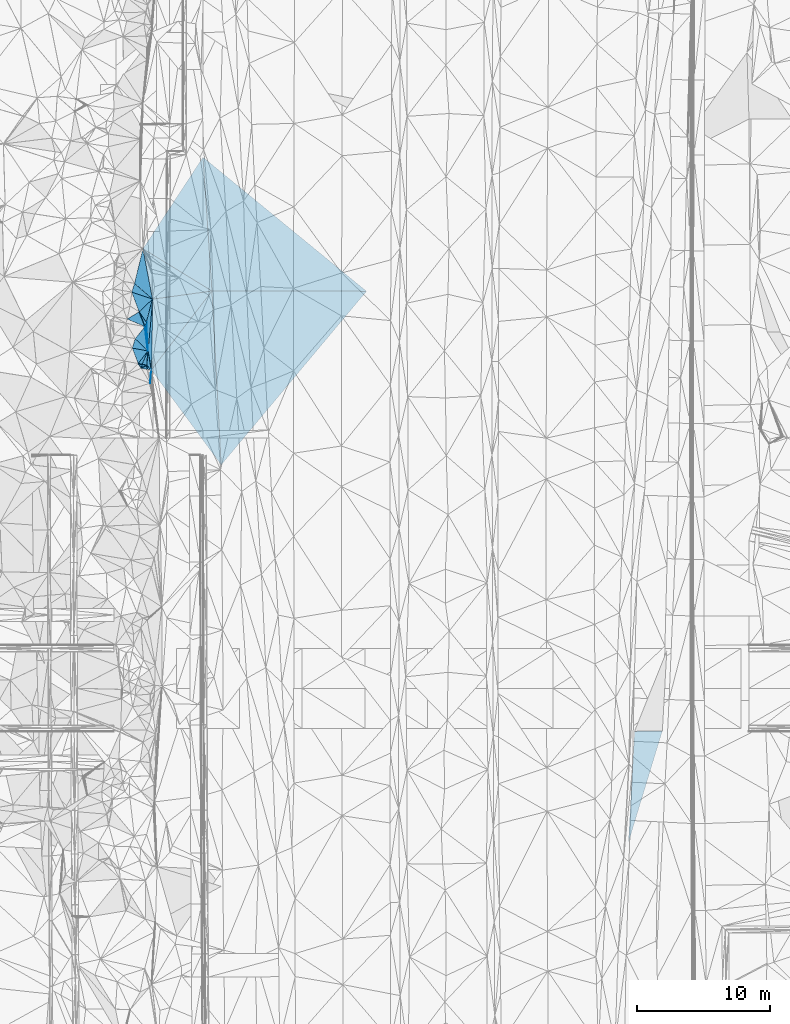
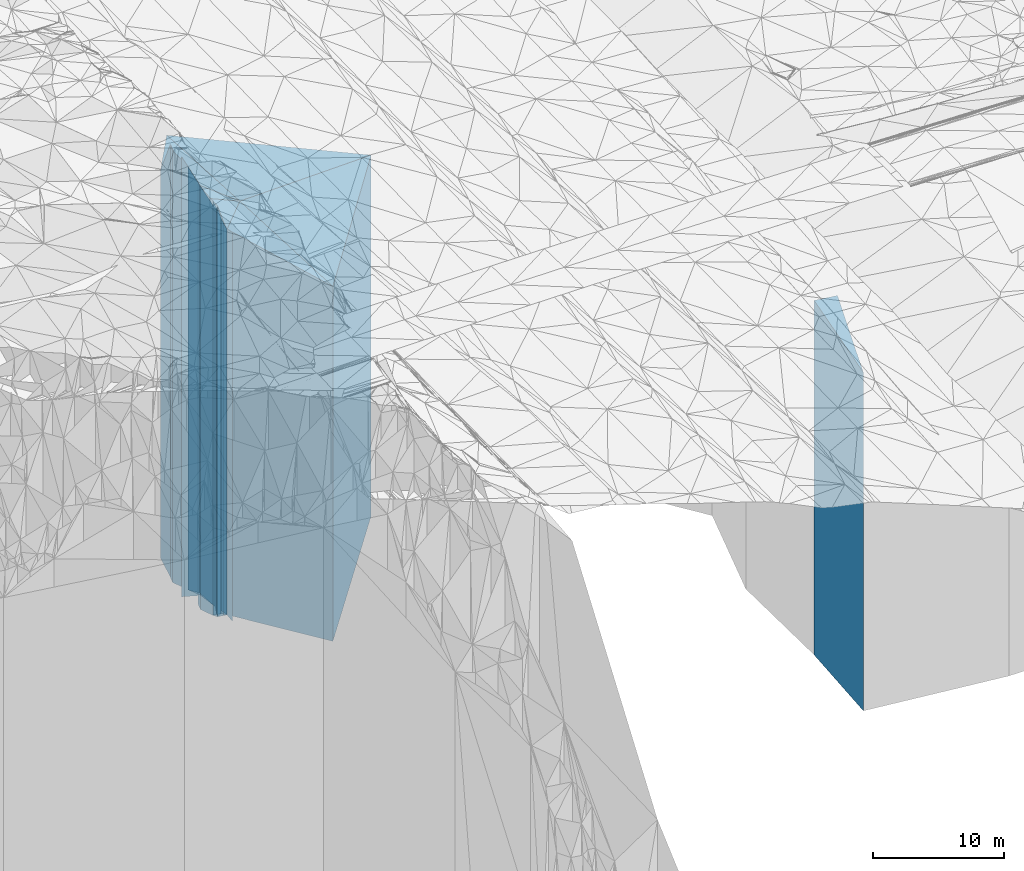
# One storey, part 252 of 275: 27 plates.
"""IFC2X3 building model written with IfcOpenShell, lengths in millimetres."""

from ifc_helpers import new_model, si_unit, frame, origin_with_axes, place, context, subcontext, project, spatial, faceted_brep, material, type_object, element, save


model = new_model("IFC2X3")

# Units and contexts
model_context = context("Model", 3, precision=1e-05, world=origin_with_axes())
body_context = subcontext(model_context, "Body", "Model", "MODEL_VIEW")
ifc_project = project(units=[si_unit("LENGTHUNIT", "METRE", prefix="MILLI"), si_unit("AREAUNIT", "SQUARE_METRE"), si_unit("VOLUMEUNIT", "CUBIC_METRE"), si_unit("MASSUNIT", "GRAM", prefix="KILO"), si_unit("TIMEUNIT", "SECOND"), si_unit("PLANEANGLEUNIT", "RADIAN"), si_unit("SOLIDANGLEUNIT", "STERADIAN"), si_unit("THERMODYNAMICTEMPERATUREUNIT", "DEGREE_CELSIUS"), si_unit("LUMINOUSINTENSITYUNIT", "LUMEN")], contexts=[model_context])

# Site, building, storey
site_placement = place(None, origin_with_axes())
site = spatial("IfcSite", under=ifc_project, at=site_placement, CompositionType="ELEMENT")
building_placement = place(site_placement, origin_with_axes())
building = spatial("IfcBuilding", under=site, at=building_placement, Name="Undefined", CompositionType="ELEMENT")
storey_placement = place(building_placement, origin_with_axes())
storey = spatial("IfcBuildingStorey", under=building, at=storey_placement, Name="Undefined", CompositionType="ELEMENT", Elevation=0.0)

# Plates
ifc_material = material()
plate_type_1 = type_object("IfcPlateType", PredefinedType="NOTDEFINED")
plate_1_placement = place(storey_placement, frame((-94152.6984096096, 103099.353531321, 24553.0), z_axis=(0.997762925662043, 0.0668516579773562, 0.0), x_axis=(0.0668516579773567, -0.997762925662043, 0.0)))
element("IfcPlate", 1, at=plate_1_placement, inside=storey, type_object=plate_type_1, material=ifc_material, Name="00", context=body_context, shape_type="Brep", body=[
    faceted_brep([(0.0, -17039.6099853516, 0.0), (10847.771484375, -16986.3760070801, 11560.4423828125), (10847.771484375, 16725.0, 11560.4423828125), (0.0, 16725.0, 0.0), (10054.0888671875, -16725.0, 7.13043846189976e-10), (10054.0888671875, 16725.0, 7.13043846189976e-10)], [[[0, 1, 2, 3]], [[1, 4, 5, 2]], [[4, 0, 3, 5]], [[5, 3, 2]], [[4, 1, 0]]]),
])
plate_type_2 = type_object("IfcPlateType", PredefinedType="NOTDEFINED")
plate_2_placement = place(storey_placement, frame((-81892.9256122936, 93048.6836211359, 24399.5), z_axis=(-0.0016459390007212, -0.999998645441486, 0.0), x_axis=(-0.999998645441486, 0.00164593900072622, 0.0)))
element("IfcPlate", 2, at=plate_2_placement, inside=storey, type_object=plate_type_2, material=ifc_material, Name="00", context=body_context, shape_type="Brep", body=[
    faceted_brep([(0.0, -17139.4489746094, -1.45519152283669e-11), (10876.5312500001, -16571.5, 13036.595703125), (10876.5312500001, 16571.5, 13036.595703125), (0.0, 16571.5, -1.45519152283669e-11), (11587.65625, -16878.0729980469, 6.53817551210523e-08), (11587.65625, 16571.5, 6.53817551210523e-08)], [[[0, 1, 2, 3]], [[1, 4, 5, 2]], [[4, 0, 3, 5]], [[5, 3, 2]], [[4, 1, 0]]]),
])
plate_type_3 = type_object("IfcPlateType", PredefinedType="NOTDEFINED")
plate_3_placement = place(storey_placement, frame((-98655.348942853, 96236.2748134191, 24553.0), z_axis=(0.982325218462175, 0.187182171088061, 0.0), x_axis=(0.187182171088067, -0.982325218462174, 0.0)))
element("IfcPlate", 3, at=plate_3_placement, inside=storey, type_object=plate_type_3, material=ifc_material, Name="00", context=body_context, shape_type="Brep", body=[
    faceted_brep([(-1.45519152283669e-11, -19539.4208984375, 0.0), (4081.14282226558, -16725.0, 4490.22949218751), (4081.14282226558, 16725.0, 4490.22949218751), (0.0, 16725.0, 0.0), (3848.62329101561, -19036.4208984375, -5.51517587155104e-09), (3848.62329101561, 16725.0, -5.51517587155104e-09)], [[[0, 1, 2, 3]], [[1, 4, 5, 2]], [[4, 0, 3, 5]], [[5, 3, 2]], [[4, 1, 0]]]),
])
plate_type_4 = type_object("IfcPlateType", PredefinedType="NOTDEFINED")
plate_4_placement = place(storey_placement, frame((-98025.9902817221, 87149.6399205856, 24399.5), z_axis=(0.805647379927931, 0.592395390947009, 0.0), x_axis=(0.592395390947008, -0.805647379927932, 0.0)))
element("IfcPlate", 4, at=plate_4_placement, inside=storey, type_object=plate_type_4, material=ifc_material, Name="00", context=body_context, shape_type="Brep", body=[
    faceted_brep([(0.0, -19435.4938964844, 1.09139364212751e-11), (-2075.22631835936, -16878.0729980469, 7167.8740234375), (-2075.22631835936, 16571.5, 7167.8740234375), (0.0, 16571.5, -1.45519152283669e-11), (8837.1572265625, -16571.5, 4.90872480440885e-08), (8837.1572265625, 16571.5, 4.90872480440885e-08)], [[[0, 1, 2, 3]], [[1, 4, 5, 2]], [[4, 0, 3, 5]], [[5, 3, 2]], [[4, 1, 0]]]),
])
plate_type_5 = type_object("IfcPlateType", PredefinedType="NOTDEFINED")
plate_5_placement = place(storey_placement, frame((-93480.5658804867, 93067.75619614, 24553.0), z_axis=(-0.997762925662043, -0.0668516579773562, 0.0), x_axis=(-0.0668516579773568, 0.997762925662043, 0.0)))
element("IfcPlate", 5, at=plate_5_placement, inside=storey, type_object=plate_type_5, material=ifc_material, Name="00", context=body_context, shape_type="Brep", body=[
    faceted_brep([(0.0, -16725.0, 1.45519152283669e-11), (3507.37329101563, -19539.4208984375, 4951.3857421875), (3507.37329101563, 16725.0, 4951.3857421875), (0.0, 16725.0, 0.0), (10054.0888671875, -17039.6099853516, 7.13043846189976e-10), (10054.0888671875, 16725.0, 7.13043846189976e-10)], [[[0, 1, 2, 3]], [[1, 4, 5, 2]], [[4, 0, 3, 5]], [[5, 3, 2]], [[4, 1, 0]]]),
])
plate_type_6 = type_object("IfcPlateType", PredefinedType="NOTDEFINED")
plate_6_placement = place(storey_placement, frame((-98025.9902817221, 87149.6399205856, 25831.5), z_axis=(0.683825970790055, -0.729645147775985, 0.0), x_axis=(-0.729645147776013, -0.683825970790025, 0.0)))
element("IfcPlate", 6, at=plate_6_placement, inside=storey, type_object=plate_type_6, material=ifc_material, Name="00", context=body_context, shape_type="Brep", body=[
    faceted_brep([(2.00088834390044e-11, -18003.5, 0.0), (742.769348144573, -18318.5, 669.195556640625), (742.769348144573, 18003.5, 669.195556640625), (0.0, 18003.5, 1.45519152283669e-11), (21.1896209716924, -18078.5, 5.82076609134674e-11), (21.1896209716924, 18003.5, 5.82076609134674e-11)], [[[0, 1, 2, 3]], [[1, 4, 5, 2]], [[4, 0, 3, 5]], [[5, 3, 2]], [[4, 1, 0]]]),
])
plate_type_7 = type_object("IfcPlateType", PredefinedType="NOTDEFINED")
plate_7_placement = place(storey_placement, frame((-98377.8508524232, 87500.3009232448, 26339.0), z_axis=(-0.202520293996895, -0.979278065985046, 0.0), x_axis=(-0.979278065985045, 0.202520293996899, 0.0)))
element("IfcPlate", 7, at=plate_7_placement, inside=storey, type_object=plate_type_7, material=ifc_material, Name="00", context=body_context, shape_type="Brep", body=[
    faceted_brep([(1.45519152283669e-11, -18511.0, -1.45519152283669e-11), (351.06787109375, -19841.0, 299.918914794915), (351.06787109375, 18511.0, 299.918914794915), (1.45519152283669e-11, 18511.0, -1.45519152283669e-11), (344.093017578125, -19481.0, -4.36557456851006e-10), (344.093017578125, 18511.0, -4.36557456851006e-10)], [[[0, 1, 2, 3]], [[1, 4, 5, 2]], [[4, 0, 3, 5]], [[5, 3, 2]], [[4, 1, 0]]]),
])
plate_type_8 = type_object("IfcPlateType", PredefinedType="NOTDEFINED")
plate_8_placement = place(storey_placement, frame((-98377.8508524232, 87500.3009232448, 26339.0), z_axis=(-0.996431835262136, 0.0844014080222094, 0.0), x_axis=(0.0844014080222022, 0.996431835262137, 0.0)))
element("IfcPlate", 8, at=plate_8_placement, inside=storey, type_object=plate_type_8, material=ifc_material, Name="00", context=body_context, shape_type="Brep", body=[
    faceted_brep([(1.45519152283669e-11, -18511.0, -1.45519152283669e-11), (40.9970359802246, -19481.0, 341.641967773438), (40.9970359802246, 18511.0, 341.641967773438), (1.45519152283669e-11, 18511.0, -1.45519152283669e-11), (1083.00512695313, -18721.0, 3.79804987460375e-09), (1083.00512695313, 18511.0, 3.79804987460375e-09)], [[[0, 1, 2, 3]], [[1, 4, 5, 2]], [[4, 0, 3, 5]], [[5, 3, 2]], [[4, 1, 0]]]),
])
plate_type_9 = type_object("IfcPlateType", PredefinedType="NOTDEFINED")
plate_9_placement = place(storey_placement, frame((-98714.8135904464, 87569.9867409115, 26444.0), z_axis=(-0.920543650335131, 0.390639716142218, 0.0), x_axis=(0.390639716142215, 0.920543650335132, 0.0)))
element("IfcPlate", 9, at=plate_9_placement, inside=storey, type_object=plate_type_9, material=ifc_material, Name="00", context=body_context, shape_type="Brep", body=[
    faceted_brep([(7.27595761418343e-12, -19376.0, 0.0), (-66.1143112182544, -20106.0, 295.00659179689), (-66.1143112182544, 18616.0, 295.00659179689), (7.27595761418343e-12, 18616.0, 0.0), (1096.58557128906, -18616.0, 1.65891833603382e-09), (1096.58557128906, 18616.0, 1.65891833603382e-09)], [[[0, 1, 2, 3]], [[1, 4, 5, 2]], [[4, 0, 3, 5]], [[5, 3, 2]], [[4, 1, 0]]]),
])
plate_type_10 = type_object("IfcPlateType", PredefinedType="NOTDEFINED")
plate_10_placement = place(storey_placement, frame((-98025.9902817221, 87149.6399205856, 25831.5), z_axis=(-0.705898354863011, -0.708313145862545, 0.0), x_axis=(-0.708313145862534, 0.705898354863022, 0.0)))
element("IfcPlate", 10, at=plate_10_placement, inside=storey, type_object=plate_type_10, material=ifc_material, Name="00", context=body_context, shape_type="Brep", body=[
    faceted_brep([(2.00088834390044e-11, -18003.5, 0.0), (236.813262939468, -18788.5, 186.891616821289), (236.813262939468, 18003.5, 186.891616821289), (0.0, 18003.5, 1.45519152283669e-11), (496.758483886762, -19018.5, 2.16823536902666e-09), (496.758483886762, 18003.5, 2.16823536902666e-09)], [[[0, 1, 2, 3]], [[1, 4, 5, 2]], [[4, 0, 3, 5]], [[5, 3, 2]], [[4, 1, 0]]]),
])
plate_type_11 = type_object("IfcPlateType", PredefinedType="NOTDEFINED")
plate_11_placement = place(storey_placement, frame((-98782.3835816159, 87277.6952831278, 26224.0), z_axis=(0.200077581912619, 0.979780057572106, 0.0), x_axis=(0.979780057572108, -0.200077581912611, 0.0)))
element("IfcPlate", 11, at=plate_11_placement, inside=storey, type_object=plate_type_11, material=ifc_material, Name="00", context=body_context, shape_type="Brep", body=[
    faceted_brep([(3.63797880709171e-12, -19956.0, 1.45519152283669e-11), (351.81469726561, -18626.0, 299.042510986314), (351.81469726561, 18396.0, 299.042510986314), (-1.45519152283669e-11, 18396.0, 1.45519152283669e-11), (466.154479980454, -18396.0, -1.60071067512035e-10), (466.154479980454, 18396.0, -1.60071067512035e-10)], [[[0, 1, 2, 3]], [[1, 4, 5, 2]], [[4, 0, 3, 5]], [[5, 3, 2]], [[4, 1, 0]]]),
])
plate_type_12 = type_object("IfcPlateType", PredefinedType="NOTDEFINED")
plate_12_placement = place(storey_placement, frame((-98714.8135904464, 87569.9867409115, 26824.0), z_axis=(-0.179873679992064, -0.983689716956578, 0.0), x_axis=(-0.983689716956578, 0.179873679992061, 0.0)))
element("IfcPlate", 12, at=plate_12_placement, inside=storey, type_object=plate_type_12, material=ifc_material, Name="00", context=body_context, shape_type="Brep", body=[
    faceted_brep([(1.45519152283669e-11, -18996.0, 0.0), (13.8923654556274, -19356.0, 299.678161621094), (13.8923654556274, 18996.0, 299.678161621094), (1.45519152283669e-11, 18996.0, 0.0), (302.324340820327, -19726.0, 9.45874489843845e-10), (302.324340820327, 18996.0, 9.45874489843845e-10)], [[[0, 1, 2, 3]], [[1, 4, 5, 2]], [[4, 0, 3, 5]], [[5, 3, 2]], [[4, 1, 0]]]),
])
plate_type_13 = type_object("IfcPlateType", PredefinedType="NOTDEFINED")
plate_13_placement = place(storey_placement, frame((-98286.4436989731, 88579.4416611924, 26444.0), z_axis=(-0.993161342957757, -0.116749932995033, 0.0), x_axis=(-0.116749932995031, 0.993161342957757, 0.0)))
element("IfcPlate", 13, at=plate_13_placement, inside=storey, type_object=plate_type_13, material=ifc_material, Name="00", context=body_context, shape_type="Brep", body=[
    faceted_brep([(-1.45519152283669e-11, -18616.0, -1.45519152283669e-11), (1018.33538818359, -20646.0, 837.492126464829), (1018.33538818359, 18616.0, 837.492126464829), (7.27595761418343e-12, 18616.0, 0.0), (1831.42016601561, -19656.0, -5.51517587155104e-09), (1831.42016601561, 18616.0, -5.51517587155104e-09)], [[[0, 1, 2, 3]], [[1, 4, 5, 2]], [[4, 0, 3, 5]], [[5, 3, 2]], [[4, 1, 0]]]),
])
plate_type_14 = type_object("IfcPlateType", PredefinedType="NOTDEFINED")
plate_14_placement = place(storey_placement, frame((-98377.8508524232, 87500.3009232448, 25831.5), z_axis=(0.705898354863011, 0.708313145862545, 0.0), x_axis=(0.708313145862548, -0.705898354863007, 0.0)))
element("IfcPlate", 14, at=plate_14_placement, inside=storey, type_object=plate_type_14, material=ifc_material, Name="00", context=body_context, shape_type="Brep", body=[
    faceted_brep([(0.0, -19018.5, 1.00044417195022e-11), (-697.018798828154, -19228.5, 828.893737792979), (-697.018798828154, 18003.5, 828.893737792979), (0.0, 18003.5, 1.45519152283669e-11), (496.758483886719, -18003.5, 2.1636878955178e-09), (496.758483886762, 18003.5, 2.16823536902666e-09)], [[[0, 1, 2, 3]], [[1, 4, 5, 2]], [[4, 0, 3, 5]], [[5, 3, 2]], [[4, 1, 0]]]),
])
plate_type_15 = type_object("IfcPlateType", PredefinedType="NOTDEFINED")
plate_15_placement = place(storey_placement, frame((-99012.2069242033, 87624.3669306589, 26444.0), z_axis=(-0.796199771042072, 0.605033821031975, 0.0), x_axis=(0.605033821031971, 0.796199771042075, 0.0)))
element("IfcPlate", 15, at=plate_15_placement, inside=storey, type_object=plate_type_15, material=ifc_material, Name="00", context=body_context, shape_type="Brep", body=[
    faceted_brep([(3.63797880709171e-12, -20106.0, 2.91038304567337e-11), (660.835754394528, -20836.0, 1051.56835937503), (660.835754394528, 18616.0, 1051.56835937503), (7.27595761418343e-12, 18616.0, 0.0), (1199.54162597657, -18616.0, 6.17001205682755e-09), (1199.54162597657, 18616.0, 6.17001205682755e-09)], [[[0, 1, 2, 3]], [[1, 4, 5, 2]], [[4, 0, 3, 5]], [[5, 3, 2]], [[4, 1, 0]]]),
])
plate_type_16 = type_object("IfcPlateType", PredefinedType="NOTDEFINED")
plate_16_placement = place(storey_placement, frame((-98286.4436989731, 88579.4416611924, 26444.0), z_axis=(-0.692912617795982, -0.7210215697877, 0.0), x_axis=(-0.721021569787703, 0.692912617795979, 0.0)))
element("IfcPlate", 16, at=plate_16_placement, inside=storey, type_object=plate_type_16, material=ifc_material, Name="00", context=body_context, shape_type="Brep", body=[
    faceted_brep([(-1.45519152283669e-11, -18616.0, -1.45519152283669e-11), (982.34033203125, -20836.0, 656.511596679693), (982.34033203125, 18616.0, 656.511596679693), (7.27595761418343e-12, 18616.0, 0.0), (1318.48400878903, -20646.0, -2.25008989218622e-09), (1318.48400878903, 18616.0, -2.25008989218622e-09)], [[[0, 1, 2, 3]], [[1, 4, 5, 2]], [[4, 0, 3, 5]], [[5, 3, 2]], [[4, 1, 0]]]),
])
plate_type_17 = type_object("IfcPlateType", PredefinedType="NOTDEFINED")
plate_17_placement = place(storey_placement, frame((-98944.9100955106, 91502.868076314, 26964.0), z_axis=(0.51471364205099, -0.857362156084933, 0.0), x_axis=(-0.857362156084931, -0.514713642050993, 0.0)))
element("IfcPlate", 17, at=plate_17_placement, inside=storey, type_object=plate_type_17, material=ifc_material, Name="00", context=body_context, shape_type="Brep", body=[
    faceted_brep([(7.27595761418343e-12, -20376.0, -1.45519152283669e-11), (187.292449951172, -19136.0, 1175.84924316405), (187.292449951172, 19136.0, 1175.84924316405), (0.0, 19136.0, 0.0), (1048.09350585938, -21966.0, -1.01717887446284e-08), (1048.09350585938, 19136.0, -1.01717887446284e-08)], [[[0, 1, 2, 3]], [[1, 4, 5, 2]], [[4, 0, 3, 5]], [[5, 3, 2]], [[4, 1, 0]]]),
])
plate_type_18 = type_object("IfcPlateType", PredefinedType="NOTDEFINED")
plate_18_placement = place(storey_placement, frame((-98386.9627014293, 90710.8486918051, 26444.0), z_axis=(0.940122716207132, -0.340836146075097, 0.0), x_axis=(-0.340836146075095, -0.940122716207133, 0.0)))
element("IfcPlate", 18, at=plate_18_placement, inside=storey, type_object=plate_type_18, material=ifc_material, Name="00", context=body_context, shape_type="Brep", body=[
    faceted_brep([(-7.27595761418343e-12, -19456.0, -1.45519152283669e-11), (1969.52368164062, -18616.0, 820.960754394517), (1969.52368164062, 18616.0, 820.960754394517), (7.27595761418343e-12, 18616.0, 0.0), (332.41540527343, -19656.0, -1.13504938781261e-09), (332.41540527343, 18616.0, -1.13504938781261e-09)], [[[0, 1, 2, 3]], [[1, 4, 5, 2]], [[4, 0, 3, 5]], [[5, 3, 2]], [[4, 1, 0]]]),
])
plate_type_19 = type_object("IfcPlateType", PredefinedType="NOTDEFINED")
plate_19_placement = place(storey_placement, frame((-98386.9627014293, 90710.8486918051, 25708.5), z_axis=(-0.968044726383583, 0.250777606099375, 0.0), x_axis=(0.250777606099367, 0.968044726383585, 0.0)))
element("IfcPlate", 19, at=plate_19_placement, inside=storey, type_object=plate_type_19, material=ifc_material, Name="00", context=body_context, shape_type="Brep", body=[
    faceted_brep([(0.0, -20191.5, 0.0), (626.789489746101, -21631.5, 738.738769531265), (626.789489746101, 17880.5, 738.738769531265), (0.0, 17880.5, 0.0), (1802.42333984374, -17880.5, -1.15105649456382e-08), (1802.42333984374, 17880.5, -1.15105649456382e-08)], [[[0, 1, 2, 3]], [[1, 4, 5, 2]], [[4, 0, 3, 5]], [[5, 3, 2]], [[4, 1, 0]]]),
])
plate_type_20 = type_object("IfcPlateType", PredefinedType="NOTDEFINED")
plate_20_placement = place(storey_placement, frame((-97934.9552841355, 92455.6751286495, 25708.5), z_axis=(0.968044726383583, -0.250777606099375, 0.0), x_axis=(-0.250777606099373, -0.968044726383584, 0.0)))
element("IfcPlate", 20, at=plate_20_placement, inside=storey, type_object=plate_type_20, material=ifc_material, Name="00", context=body_context, shape_type="Brep", body=[
    faceted_brep([(-1.45519152283669e-11, -17880.5, 0.0), (3840.5126953125, -19351.5, 631.816040039063), (3840.5126953125, 17880.5, 631.816040039063), (0.0, 17880.5, 0.0), (1802.42333984375, -20191.5, -1.15251168608665e-08), (1802.42333984374, 17880.5, -1.15105649456382e-08)], [[[0, 1, 2, 3]], [[1, 4, 5, 2]], [[4, 0, 3, 5]], [[5, 3, 2]], [[4, 1, 0]]]),
])
plate_type_21 = type_object("IfcPlateType", PredefinedType="NOTDEFINED")
plate_21_placement = place(storey_placement, frame((-98500.261886087, 90398.3374203989, 26864.0), z_axis=(-0.940122716207132, 0.340836146075097, 0.0), x_axis=(0.340836146075109, 0.940122716207127, 0.0)))
element("IfcPlate", 21, at=plate_21_placement, inside=storey, type_object=plate_type_21, material=ifc_material, Name="00", context=body_context, shape_type="Brep", body=[
    faceted_brep([(-1.45519152283669e-11, -19236.0, 0.0), (886.842163085952, -20476.0, 794.487854003921), (886.842163085952, 19036.0, 794.487854003921), (7.27595761418343e-12, 19036.0, 1.45519152283669e-11), (332.41540527343, -19036.0, -1.12049747258425e-09), (332.41540527343, 19036.0, -1.12049747258425e-09)], [[[0, 1, 2, 3]], [[1, 4, 5, 2]], [[4, 0, 3, 5]], [[5, 3, 2]], [[4, 1, 0]]]),
])
plate_type_22 = type_object("IfcPlateType", PredefinedType="NOTDEFINED")
plate_22_placement = place(storey_placement, frame((-98286.4436989731, 88579.4416611924, 25708.5), z_axis=(0.983810581415163, 0.179211439075633, 0.0), x_axis=(0.179211439075626, -0.983810581415164, 0.0)))
element("IfcPlate", 22, at=plate_22_placement, inside=storey, type_object=plate_type_22, material=ifc_material, Name="00", context=body_context, shape_type="Brep", body=[
    faceted_brep([(-1.45519152283669e-11, -19351.5, -1.45519152283669e-11), (-3750.48876953125, -17880.5, 1040.46337890625), (-3750.48876953125, 17880.5, 1040.46337890625), (0.0, 17880.5, 0.0), (1453.33032226561, -18126.5, -6.72298483550549e-09), (1453.33032226561, 17880.5, -6.72298483550549e-09)], [[[0, 1, 2, 3]], [[1, 4, 5, 2]], [[4, 0, 3, 5]], [[5, 3, 2]], [[4, 1, 0]]]),
])
plate_type_23 = type_object("IfcPlateType", PredefinedType="NOTDEFINED")
plate_23_placement = place(storey_placement, frame((-98944.9100955106, 91502.868076314, 25708.5), z_axis=(-0.686227855924535, 0.72738664392001, 0.0), x_axis=(0.72738664392001, 0.686227855924535, 0.0)))
element("IfcPlate", 23, at=plate_23_placement, inside=storey, type_object=plate_type_23, material=ifc_material, Name="00", context=body_context, shape_type="Brep", body=[
    faceted_brep([(1.2732925824821e-11, -21631.5, 0.0), (617.809387207029, -22471.5, 1446.79357910156), (617.809387207029, 17880.5, 1446.79357910156), (0.0, 17880.5, 0.0), (1388.47033691408, -17880.5, -4.71482053399086e-09), (1388.47033691408, 17880.5, -4.71482053399086e-09)], [[[0, 1, 2, 3]], [[1, 4, 5, 2]], [[4, 0, 3, 5]], [[5, 3, 2]], [[4, 1, 0]]]),
])
plate_type_24 = type_object("IfcPlateType", PredefinedType="NOTDEFINED")
plate_24_placement = place(storey_placement, frame((-99488.353856279, 92979.2043790858, 25708.5), z_axis=(0.3193718340451, 0.947629480133807, 0.0), x_axis=(0.947629480133809, -0.319371834045095, 0.0)))
element("IfcPlate", 24, at=plate_24_placement, inside=storey, type_object=plate_type_24, material=ifc_material, Name="00", context=body_context, shape_type="Brep", body=[
    faceted_brep([(1.45519152283669e-11, -22471.5, 0.0), (-19.2710456847999, -22571.5, 687.407165527329), (-19.2710456847999, 17880.5, 687.407165527329), (0.0, 17880.5, 0.0), (1639.24682617188, -17880.5, -7.13771441951394e-09), (1639.24682617188, 17880.5, -7.13771441951394e-09)], [[[0, 1, 2, 3]], [[1, 4, 5, 2]], [[4, 0, 3, 5]], [[5, 3, 2]], [[4, 1, 0]]]),
])
plate_type_25 = type_object("IfcPlateType", PredefinedType="NOTDEFINED")
plate_25_placement = place(storey_placement, frame((-99287.0771765594, 93636.7663139642, 25708.5), z_axis=(0.657868553810078, 0.753132767782571, 0.0), x_axis=(0.753132767782574, -0.657868553810075, 0.0)))
element("IfcPlate", 25, at=plate_25_placement, inside=storey, type_object=plate_type_25, material=ifc_material, Name="00", context=body_context, shape_type="Brep", body=[
    faceted_brep([(0.0, -22571.5, -1.00044417195022e-11), (-1234.35961914063, -18383.5, 2373.36914062498), (-1234.35961914063, 17880.5, 2373.36914062498), (0.0, 17880.5, 0.0), (1795.330078125, -17880.5, 3.75166564481333e-09), (1795.330078125, 17880.5, 3.75166564481333e-09)], [[[0, 1, 2, 3]], [[1, 4, 5, 2]], [[4, 0, 3, 5]], [[5, 3, 2]], [[4, 1, 0]]]),
])
plate_type_26 = type_object("IfcPlateType", PredefinedType="NOTDEFINED")
plate_26_placement = place(storey_placement, frame((-93480.5658804867, 93067.75619614, 24553.0), z_axis=(0.13613157895652, -0.990690765683624, 0.0), x_axis=(-0.990690765683623, -0.136131578956528, 0.0)))
element("IfcPlate", 26, at=plate_26_placement, inside=storey, type_object=plate_type_26, material=ifc_material, Name="00", context=body_context, shape_type="Brep", body=[
    faceted_brep([(0.0, -16725.0, 1.45519152283669e-11), (5308.75244140621, -19282.4208984375, 5244.24755859375), (5308.75244140621, 16725.0, 5244.24755859375), (0.0, 16725.0, 0.0), (4496.24609375001, -19036.4208984375, 3.84170562028885e-09), (4496.24609375001, 16725.0, 3.84170562028885e-09)], [[[0, 1, 2, 3]], [[1, 4, 5, 2]], [[4, 0, 3, 5]], [[5, 3, 2]], [[4, 1, 0]]]),
])
plate_type_27 = type_object("IfcPlateType", PredefinedType="NOTDEFINED")
plate_27_placement = place(storey_placement, frame((-59726.811021383, 60101.0088580246, 23623.0), z_axis=(0.0132118559950026, -0.999912719621652, 0.0), x_axis=(-0.999912719621652, -0.0132118559950022, 0.0)))
element("IfcPlate", 27, at=plate_27_placement, inside=storey, type_object=plate_type_27, material=ifc_material, Name="00", context=body_context, shape_type="Brep", body=[
    faceted_brep([(0.0, -17021.5469970703, 0.0), (2661.53051757814, -15795.0, 8354.40332031249), (2661.53051757814, 15795.0, 8354.40332031249), (0.0, 15795.0, 0.0), (2083.44018554688, -17307.0, 3.23780113831162e-09), (2083.44018554688, 15795.0, 3.23780113831162e-09)], [[[0, 1, 2, 3]], [[1, 4, 5, 2]], [[4, 0, 3, 5]], [[5, 3, 2]], [[4, 1, 0]]]),
])

save(model, "model.ifc")
